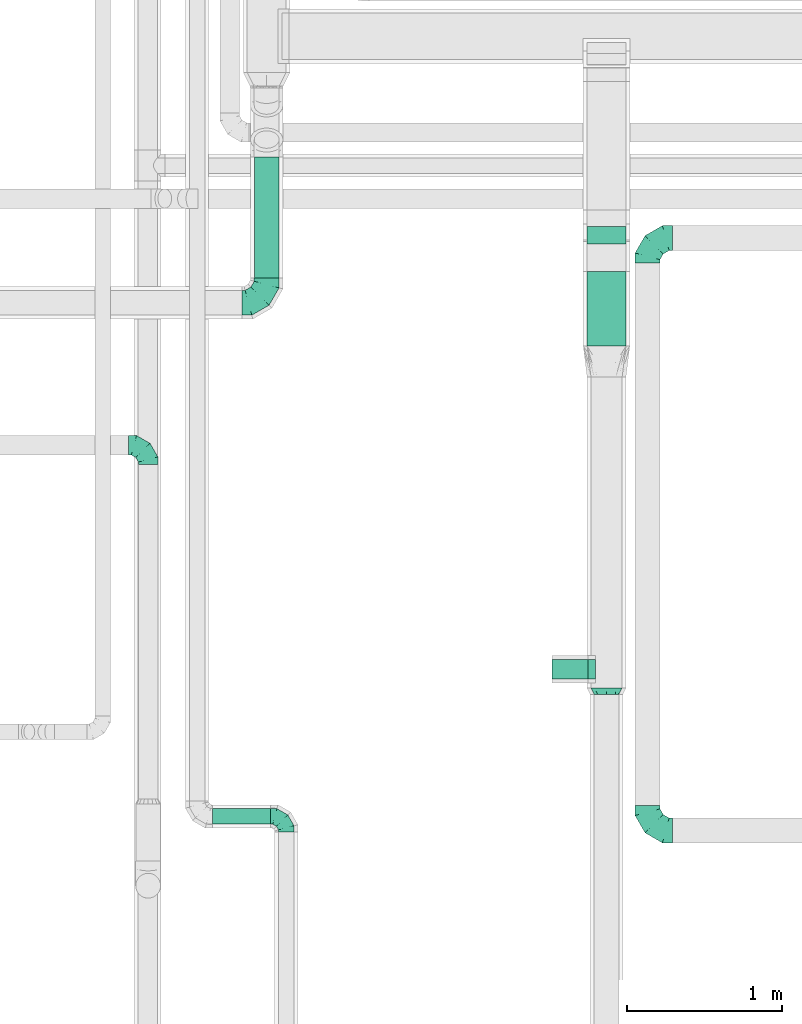
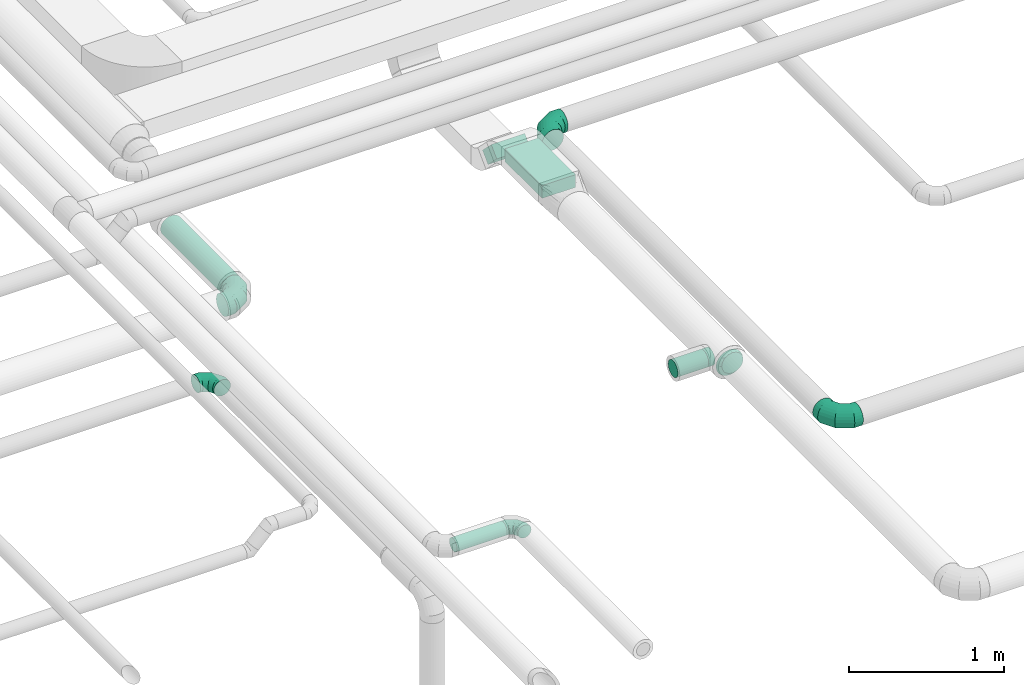
# One storey, part 61 of 92: 7 flow fittings, 5 flow segments.
"""IFC2X3 building model written with IfcOpenShell, lengths in millimetres."""

from ifc_helpers import new_model, entity, si_unit, converted_unit, derived_unit, direction, frame, origin, origin_2d_with_axis, place, context, subcontext, project, spatial, rectangle, circle, extrude, faceted_brep, source, transform, mapped, material, type_object, type_shapes, element, save


model = new_model("IFC2X3")

# Units and contexts
model_context = context("Model", 3, precision=0.01, world=origin(), true_north=direction((6.12303176911189e-17, 1.0)))
body_context = subcontext(model_context, "Body", "Model", "MODEL_VIEW")
ifc_project = project(units=[si_unit("LENGTHUNIT", "METRE", prefix="MILLI"), si_unit("AREAUNIT", "SQUARE_METRE"), si_unit("VOLUMEUNIT", "CUBIC_METRE"), converted_unit("PLANEANGLEUNIT", "DEGREE", entity("IfcRatioMeasure", 0.0174532925199433), si_unit("PLANEANGLEUNIT", "RADIAN"), dimensions=[0, 0, 0, 0, 0, 0, 0]), si_unit("MASSUNIT", "GRAM", prefix="KILO"), derived_unit("MASSDENSITYUNIT", [(si_unit("MASSUNIT", "GRAM", prefix="KILO"), 1), (si_unit("LENGTHUNIT", "METRE"), -3)]), derived_unit("MOMENTOFINERTIAUNIT", [(si_unit("LENGTHUNIT", "METRE"), 4)]), si_unit("TIMEUNIT", "SECOND"), si_unit("FREQUENCYUNIT", "HERTZ"), si_unit("THERMODYNAMICTEMPERATUREUNIT", "DEGREE_CELSIUS"), derived_unit("THERMALTRANSMITTANCEUNIT", [(si_unit("MASSUNIT", "GRAM", prefix="KILO"), 1), (si_unit("THERMODYNAMICTEMPERATUREUNIT", "KELVIN"), -1), (si_unit("TIMEUNIT", "SECOND"), -3)]), derived_unit("VOLUMETRICFLOWRATEUNIT", [(si_unit("LENGTHUNIT", "METRE"), 3), (si_unit("TIMEUNIT", "SECOND"), -1)]), derived_unit("MASSFLOWRATEUNIT", [(si_unit("MASSUNIT", "GRAM", prefix="KILO"), 1), (si_unit("TIMEUNIT", "SECOND"), -1)]), derived_unit("ROTATIONALFREQUENCYUNIT", [(si_unit("TIMEUNIT", "SECOND"), -1)]), si_unit("ELECTRICCURRENTUNIT", "AMPERE"), si_unit("ELECTRICVOLTAGEUNIT", "VOLT"), si_unit("POWERUNIT", "WATT"), si_unit("FORCEUNIT", "NEWTON", prefix="KILO"), si_unit("ILLUMINANCEUNIT", "LUX"), si_unit("LUMINOUSFLUXUNIT", "LUMEN"), si_unit("LUMINOUSINTENSITYUNIT", "CANDELA"), derived_unit("USERDEFINED", [(si_unit("MASSUNIT", "GRAM", prefix="KILO"), -1), (si_unit("LENGTHUNIT", "METRE"), -2), (si_unit("TIMEUNIT", "SECOND"), 3), (si_unit("LUMINOUSFLUXUNIT", "LUMEN"), 1)]), derived_unit("LINEARVELOCITYUNIT", [(si_unit("LENGTHUNIT", "METRE"), 1), (si_unit("TIMEUNIT", "SECOND"), -1)]), si_unit("PRESSUREUNIT", "PASCAL"), derived_unit("USERDEFINED", [(si_unit("LENGTHUNIT", "METRE"), -2), (si_unit("MASSUNIT", "GRAM", prefix="KILO"), 1), (si_unit("TIMEUNIT", "SECOND"), -2)]), derived_unit("LINEARFORCEUNIT", [(si_unit("MASSUNIT", "GRAM", prefix="KILO"), 1), (si_unit("LENGTHUNIT", "METRE"), 1), (si_unit("TIMEUNIT", "SECOND"), -2), (si_unit("LENGTHUNIT", "METRE"), -1)]), derived_unit("PLANARFORCEUNIT", [(si_unit("MASSUNIT", "GRAM", prefix="KILO"), 1), (si_unit("LENGTHUNIT", "METRE"), 1), (si_unit("TIMEUNIT", "SECOND"), -2), (si_unit("LENGTHUNIT", "METRE"), -2)])], contexts=[model_context])

# Site, building, storey
site_placement = place(None, origin())
site = spatial("IfcSite", under=ifc_project, at=site_placement, CompositionType="ELEMENT")
building_placement = place(site_placement, origin())
building = spatial("IfcBuilding", under=site, at=building_placement, CompositionType="ELEMENT")
storey_placement = place(building_placement, frame((0.0, 0.0, 4200.0)))
storey = spatial("IfcBuildingStorey", under=building, at=storey_placement, CompositionType="ELEMENT", Elevation=4200.0)

# Flow segments
duct_segment_type_1 = type_object("IfcDuctSegmentType", PredefinedType="NOTDEFINED")
flow_segment_1_placement = place(storey_placement, frame((63146.35, 7581.43, 3200.0)))
element("IfcFlowSegment", 1, at=flow_segment_1_placement, inside=storey, type_object=duct_segment_type_1, context=body_context, shape_type="SweptSolid", body=[
    extrude(rectangle(XDim=479.437287525339, YDim=250.000000000004, at=origin_2d_with_axis()), frame((125.0, 239.72, 0.0), z_axis=(0.0, 0.0, 1.0), x_axis=(0.0, 1.0, 0.0)), (0.0, 0.0, 1.0), 99.9999999999989),
])
flow_segment_2_placement = place(storey_placement, frame((63146.35, 8166.93, 3043.22)))
element("IfcFlowSegment", 2, at=flow_segment_2_placement, inside=storey, type_object=duct_segment_type_1, context=body_context, shape_type="SweptSolid", body=[
    extrude(rectangle(XDim=159.583694396644, YDim=100.000000000001, at=origin_2d_with_axis()), frame((0.0, 91.78, 91.78), z_axis=(1.0, 0.0, 0.0), x_axis=(0.0, -0.707106781186456, 0.707106781186639)), (0.0, 0.0, 1.0), 249.999999999995),
])
duct_segment_type_2 = type_object("IfcDuctSegmentType", PredefinedType="NOTDEFINED")
flow_segment_3_placement = place(storey_placement, frame((62921.35, 5437.67, 3135.9)))
element("IfcFlowSegment", 3, at=flow_segment_3_placement, inside=storey, type_object=duct_segment_type_2, context=body_context, shape_type="SweptSolid", body=[
    extrude(circle(Radius=62.5, at=origin_2d_with_axis()), frame((0.0, 64.1, 64.1), z_axis=(1.0, 0.0, 0.0), x_axis=(0.0, 1.0, 0.0)), (0.0, 0.0, 1.0), 230.000000000112),
])
flow_segment_4_placement = place(storey_placement, frame((60737.13, 4503.9, 3098.4)))
element("IfcFlowSegment", 4, at=flow_segment_4_placement, inside=storey, type_object=duct_segment_type_2, context=body_context, shape_type="SweptSolid", body=[
    extrude(circle(Radius=50.0, at=origin_2d_with_axis()), frame((0.0, 51.6, 51.6), z_axis=(1.0, 0.0, 0.0), x_axis=(0.0, -1.0, 0.0)), (0.0, 0.0, 1.0), 373.842510000017),
])
flow_segment_5_placement = place(storey_placement, frame((61003.4, 8019.85, 2888.4)))
element("IfcFlowSegment", 5, at=flow_segment_5_placement, inside=storey, type_object=duct_segment_type_2, context=body_context, shape_type="SweptSolid", body=[
    extrude(circle(Radius=80.0, at=origin_2d_with_axis()), frame((81.6, 0.0, 81.6), z_axis=(0.0, 1.0, 0.0), x_axis=(1.0, 0.0, 0.0)), (0.0, 0.0, 1.0), 776.794777815468),
])

# Flow fittings
ifc_material = material()
duct_fitting_type_1 = type_object("IfcDuctFittingType", PredefinedType="NOTDEFINED", material=ifc_material)
shared_shape_1 = source(origin(), body_context, "Body", "Brep", [
    faceted_brep([(-160.0, 0.0, -80.0), (-160.0, -20.71, -77.27), (-160.0, -40.0, -69.28), (-160.0, -56.57, -56.57), (-160.0, -69.28, -40.0), (-160.0, -77.27, -20.71), (-160.0, -80.0, 0.0), (-160.0, -77.27, 20.71), (-160.0, -69.28, 40.0), (-160.0, -56.57, 56.57), (-160.0, -40.0, 69.28), (-160.0, -20.71, 77.27), (-160.0, 0.0, 80.0), (-160.0, 20.71, 77.27), (-160.0, 40.0, 69.28), (-160.0, 56.57, 56.57), (-160.0, 69.28, 40.0), (-160.0, 77.27, 20.71), (-160.0, 80.0, 0.0), (-160.0, 77.27, -20.71), (-160.0, 69.28, -40.0), (-160.0, 56.57, -56.57), (-160.0, 40.0, -69.28), (-160.0, 20.71, -77.27), (-122.68, 20.71, 77.27), (-127.85, 40.0, 69.28), (-117.13, 0.0, 80.0), (-132.29, 56.57, 56.57), (-137.83, 77.27, 20.71), (-138.56, 80.0, 0.0), (-135.69, 69.28, 40.0), (-135.69, 69.28, -40.0), (-132.29, 56.57, -56.57), (-137.83, 77.27, -20.71), (-122.68, 20.71, -77.27), (-117.13, 0.0, -80.0), (-127.85, 40.0, -69.28), (-111.58, -20.71, -77.27), (-106.41, -40.0, -69.28), (-101.97, -56.57, -56.57), (-98.56, -69.28, -40.0), (-96.42, -77.27, -20.71), (-95.69, -80.0, 0.0), (-96.42, -77.27, 20.71), (-98.56, -69.28, 40.0), (-101.97, -56.57, 56.57), (-106.41, -40.0, 69.28), (-111.58, -20.71, 77.27), (-58.03, 58.03, 77.27), (-72.15, 72.15, 69.28), (-42.87, 42.87, 80.0), (-84.28, 84.28, 56.57), (-93.59, 93.59, 40.0), (-99.44, 99.44, 20.71), (-101.44, 101.44, 0.0), (-99.44, 99.44, -20.71), (-93.59, 93.59, -40.0), (-84.28, 84.28, -56.57), (-58.03, 58.03, -77.27), (-42.87, 42.87, -80.0), (-72.15, 72.15, -69.28), (-27.71, 27.71, -77.27), (-13.59, 13.59, -69.28), (-1.46, 1.46, -56.57), (7.85, -7.85, -40.0), (13.7, -13.7, -20.71), (15.69, -15.69, 0.0), (13.7, -13.7, 20.71), (7.85, -7.85, 40.0), (-1.46, 1.46, 56.57), (-13.59, 13.59, 69.28), (-27.71, 27.71, 77.27), (-20.71, 122.68, 77.27), (-40.0, 127.85, 69.28), (0.0, 117.13, 80.0), (-56.57, 132.29, 56.57), (-69.28, 135.69, 40.0), (-77.27, 137.83, 20.71), (-80.0, 138.56, 0.0), (-77.27, 137.83, -20.71), (-69.28, 135.69, -40.0), (-56.57, 132.29, -56.57), (-20.71, 122.68, -77.27), (0.0, 117.13, -80.0), (-40.0, 127.85, -69.28), (20.71, 111.58, -77.27), (40.0, 106.41, -69.28), (56.57, 101.97, -56.57), (69.28, 98.56, -40.0), (77.27, 96.42, -20.71), (80.0, 95.69, 0.0), (77.27, 96.42, 20.71), (69.28, 98.56, 40.0), (56.57, 101.97, 56.57), (40.0, 106.41, 69.28), (20.71, 111.58, 77.27), (-20.71, 160.0, -77.27), (-40.0, 160.0, -69.28), (-56.57, 160.0, -56.57), (-69.28, 160.0, -40.0), (-77.27, 160.0, -20.71), (-80.0, 160.0, 0.0), (-77.27, 160.0, 20.71), (-69.28, 160.0, 40.0), (-56.57, 160.0, 56.57), (-40.0, 160.0, 69.28), (-20.71, 160.0, 77.27), (0.0, 160.0, 80.0), (20.71, 160.0, 77.27), (40.0, 160.0, 69.28), (56.57, 160.0, 56.57), (69.28, 160.0, 40.0), (77.27, 160.0, 20.71), (80.0, 160.0, 0.0), (77.27, 160.0, -20.71), (69.28, 160.0, -40.0), (56.57, 160.0, -56.57), (40.0, 160.0, -69.28), (20.71, 160.0, -77.27), (0.0, 160.0, -80.0)], [[[0, 1, 2, 3, 4, 5, 6, 7, 8, 9, 10, 11, 12, 13, 14, 15, 16, 17, 18, 19, 20, 21, 22, 23]], [[24, 25, 14, 13]], [[26, 24, 13, 12]], [[14, 25, 27, 15]], [[28, 29, 18, 17]], [[30, 28, 17, 16]], [[15, 27, 30, 16]], [[20, 31, 32, 21]], [[33, 31, 20, 19]], [[18, 29, 33, 19]], [[34, 35, 0, 23]], [[36, 34, 23, 22]], [[32, 36, 22, 21]], [[1, 0, 35, 37]], [[2, 1, 37, 38]], [[3, 2, 38, 39]], [[5, 4, 40, 41]], [[6, 5, 41, 42]], [[39, 40, 4, 3]], [[6, 42, 43, 7]], [[7, 43, 44, 8]], [[8, 44, 45, 9]], [[9, 45, 46, 10]], [[10, 46, 47, 11]], [[26, 12, 11, 47]], [[48, 49, 25, 24]], [[50, 48, 24, 26]], [[27, 25, 49, 51]], [[52, 53, 28, 30]], [[51, 52, 30, 27]], [[29, 28, 53, 54]], [[55, 56, 31, 33]], [[54, 55, 33, 29]], [[32, 31, 56, 57]], [[58, 59, 35, 34]], [[60, 58, 34, 36]], [[57, 60, 36, 32]], [[37, 35, 59, 61]], [[38, 37, 61, 62]], [[39, 38, 62, 63]], [[41, 40, 64, 65]], [[42, 41, 65, 66]], [[63, 64, 40, 39]], [[43, 42, 66, 67]], [[44, 43, 67, 68]], [[68, 69, 45, 44]], [[46, 45, 69, 70]], [[47, 46, 70, 71]], [[26, 47, 71, 50]], [[72, 73, 49, 48]], [[74, 72, 48, 50]], [[51, 49, 73, 75]], [[76, 77, 53, 52]], [[75, 76, 52, 51]], [[54, 53, 77, 78]], [[79, 80, 56, 55]], [[78, 79, 55, 54]], [[57, 56, 80, 81]], [[82, 83, 59, 58]], [[84, 82, 58, 60]], [[81, 84, 60, 57]], [[61, 59, 83, 85]], [[62, 61, 85, 86]], [[63, 62, 86, 87]], [[65, 64, 88, 89]], [[66, 65, 89, 90]], [[87, 88, 64, 63]], [[67, 66, 90, 91]], [[68, 67, 91, 92]], [[92, 93, 69, 68]], [[70, 69, 93, 94]], [[71, 70, 94, 95]], [[50, 71, 95, 74]], [[96, 97, 98, 99, 100, 101, 102, 103, 104, 105, 106, 107, 108, 109, 110, 111, 112, 113, 114, 115, 116, 117, 118, 119]], [[72, 74, 107, 106]], [[73, 72, 106, 105]], [[75, 73, 105, 104]], [[77, 76, 103, 102]], [[78, 77, 102, 101]], [[75, 104, 103, 76]], [[78, 101, 100, 79]], [[79, 100, 99, 80]], [[80, 99, 98, 81]], [[84, 97, 96, 82]], [[82, 96, 119, 83]], [[84, 81, 98, 97]], [[118, 117, 86, 85]], [[119, 118, 85, 83]], [[116, 87, 86, 117]], [[88, 115, 114, 89]], [[89, 114, 113, 90]], [[115, 88, 87, 116]], [[112, 111, 92, 91]], [[113, 112, 91, 90]], [[111, 110, 93, 92]], [[95, 94, 109, 108]], [[74, 95, 108, 107]], [[110, 109, 94, 93]]]),
])
type_shapes(duct_fitting_type_1, [shared_shape_1])
for number, where, z_axis, x_axis in (
    (6, (63535.27, 4465.46, 3200.0), (0.0, 0.0, 1.0), (0.0, -1.0, 0.0)),
    (7, (63535.27, 8275.8, 3200.0), (0.0, 0.0, 1.0), (-1.0, 0.0, 0.0)),
):
    element("IfcFlowFitting", number, at=place(storey_placement, frame(where, z_axis=z_axis, x_axis=x_axis)), inside=storey, type_object=duct_fitting_type_1, material=ifc_material, context=body_context, shape_type="MappedRepresentation", body=[
        mapped(shared_shape_1, transform((0.0, 0.0, 0.0), scale=1.0)),
    ])
flow_fitting_1_placement = place(storey_placement, frame((61085.0, 7859.85, 2970.0)))
element("IfcFlowFitting", 8, at=flow_fitting_1_placement, inside=storey, type_object=duct_fitting_type_1, material=ifc_material, context=body_context, shape_type="MappedRepresentation", body=[
    mapped(shared_shape_1, transform((0.0, 0.0, 0.0), scale=1.0)),
])
duct_fitting_type_2 = type_object("IfcDuctFittingType", PredefinedType="NOTDEFINED", material=ifc_material)
shared_shape_2 = source(origin(), body_context, "Body", "Brep", [
    faceted_brep([(-100.0, 0.0, -50.0), (-100.0, -12.94, -48.3), (-100.0, -25.0, -43.3), (-100.0, -35.36, -35.36), (-100.0, -43.3, -25.0), (-100.0, -48.3, -12.94), (-100.0, -50.0, 0.0), (-100.0, -48.3, 12.94), (-100.0, -43.3, 25.0), (-100.0, -35.36, 35.36), (-100.0, -25.0, 43.3), (-100.0, -12.94, 48.3), (-100.0, 0.0, 50.0), (-100.0, 12.94, 48.3), (-100.0, 25.0, 43.3), (-100.0, 35.36, 35.36), (-100.0, 43.3, 25.0), (-100.0, 48.3, 12.94), (-100.0, 50.0, 0.0), (-100.0, 48.3, -12.94), (-100.0, 43.3, -25.0), (-100.0, 35.36, -35.36), (-100.0, 25.0, -43.3), (-100.0, 12.94, -48.3), (-76.67, 12.94, 48.3), (-79.9, 25.0, 43.3), (-73.21, 0.0, 50.0), (-82.68, 35.36, 35.36), (-86.15, 48.3, 12.94), (-86.6, 50.0, 0.0), (-84.81, 43.3, 25.0), (-84.81, 43.3, -25.0), (-82.68, 35.36, -35.36), (-86.15, 48.3, -12.94), (-76.67, 12.94, -48.3), (-73.21, 0.0, -50.0), (-79.9, 25.0, -43.3), (-69.74, -12.94, -48.3), (-66.51, -25.0, -43.3), (-63.73, -35.36, -35.36), (-61.6, -43.3, -25.0), (-60.26, -48.3, -12.94), (-59.81, -50.0, 0.0), (-60.26, -48.3, 12.94), (-61.6, -43.3, 25.0), (-63.73, -35.36, 35.36), (-66.51, -25.0, 43.3), (-69.74, -12.94, 48.3), (-36.27, 36.27, 48.3), (-45.1, 45.1, 43.3), (-26.79, 26.79, 50.0), (-52.68, 52.68, 35.36), (-58.49, 58.49, 25.0), (-62.15, 62.15, 12.94), (-63.4, 63.4, 0.0), (-62.15, 62.15, -12.94), (-58.49, 58.49, -25.0), (-52.68, 52.68, -35.36), (-36.27, 36.27, -48.3), (-26.79, 26.79, -50.0), (-45.1, 45.1, -43.3), (-17.32, 17.32, -48.3), (-8.49, 8.49, -43.3), (-0.91, 0.91, -35.36), (4.9, -4.9, -25.0), (8.56, -8.56, -12.94), (9.81, -9.81, 0.0), (8.56, -8.56, 12.94), (4.9, -4.9, 25.0), (-0.91, 0.91, 35.36), (-8.49, 8.49, 43.3), (-17.32, 17.32, 48.3), (-12.94, 76.67, 48.3), (-25.0, 79.9, 43.3), (0.0, 73.21, 50.0), (-35.36, 82.68, 35.36), (-43.3, 84.81, 25.0), (-48.3, 86.15, 12.94), (-50.0, 86.6, 0.0), (-48.3, 86.15, -12.94), (-43.3, 84.81, -25.0), (-35.36, 82.68, -35.36), (-12.94, 76.67, -48.3), (0.0, 73.21, -50.0), (-25.0, 79.9, -43.3), (12.94, 69.74, -48.3), (25.0, 66.51, -43.3), (35.36, 63.73, -35.36), (43.3, 61.6, -25.0), (48.3, 60.26, -12.94), (50.0, 59.81, 0.0), (48.3, 60.26, 12.94), (43.3, 61.6, 25.0), (35.36, 63.73, 35.36), (25.0, 66.51, 43.3), (12.94, 69.74, 48.3), (-12.94, 100.0, -48.3), (-25.0, 100.0, -43.3), (-35.36, 100.0, -35.36), (-43.3, 100.0, -25.0), (-48.3, 100.0, -12.94), (-50.0, 100.0, 0.0), (-48.3, 100.0, 12.94), (-43.3, 100.0, 25.0), (-35.36, 100.0, 35.36), (-25.0, 100.0, 43.3), (-12.94, 100.0, 48.3), (0.0, 100.0, 50.0), (12.94, 100.0, 48.3), (25.0, 100.0, 43.3), (35.36, 100.0, 35.36), (43.3, 100.0, 25.0), (48.3, 100.0, 12.94), (50.0, 100.0, 0.0), (48.3, 100.0, -12.94), (43.3, 100.0, -25.0), (35.36, 100.0, -35.36), (25.0, 100.0, -43.3), (12.94, 100.0, -48.3), (0.0, 100.0, -50.0)], [[[0, 1, 2, 3, 4, 5, 6, 7, 8, 9, 10, 11, 12, 13, 14, 15, 16, 17, 18, 19, 20, 21, 22, 23]], [[24, 25, 14, 13]], [[26, 24, 13, 12]], [[14, 25, 27, 15]], [[28, 29, 18, 17]], [[30, 28, 17, 16]], [[15, 27, 30, 16]], [[20, 31, 32, 21]], [[33, 31, 20, 19]], [[18, 29, 33, 19]], [[34, 35, 0, 23]], [[36, 34, 23, 22]], [[32, 36, 22, 21]], [[2, 1, 37, 38]], [[3, 2, 38, 39]], [[0, 35, 37, 1]], [[5, 4, 40, 41]], [[6, 5, 41, 42]], [[3, 39, 40, 4]], [[6, 42, 43, 7]], [[7, 43, 44, 8]], [[8, 44, 45, 9]], [[10, 46, 47, 11]], [[11, 47, 26, 12]], [[10, 9, 45, 46]], [[48, 49, 25, 24]], [[50, 48, 24, 26]], [[27, 25, 49, 51]], [[52, 53, 28, 30]], [[51, 52, 30, 27]], [[29, 28, 53, 54]], [[55, 56, 31, 33]], [[54, 55, 33, 29]], [[57, 32, 31, 56]], [[58, 59, 35, 34]], [[60, 58, 34, 36]], [[57, 60, 36, 32]], [[37, 35, 59, 61]], [[38, 37, 61, 62]], [[39, 38, 62, 63]], [[41, 40, 64, 65]], [[42, 41, 65, 66]], [[63, 64, 40, 39]], [[43, 42, 66, 67]], [[44, 43, 67, 68]], [[68, 69, 45, 44]], [[46, 45, 69, 70]], [[47, 46, 70, 71]], [[26, 47, 71, 50]], [[72, 73, 49, 48]], [[74, 72, 48, 50]], [[51, 49, 73, 75]], [[76, 77, 53, 52]], [[75, 76, 52, 51]], [[54, 53, 77, 78]], [[79, 80, 56, 55]], [[78, 79, 55, 54]], [[81, 57, 56, 80]], [[82, 83, 59, 58]], [[84, 82, 58, 60]], [[81, 84, 60, 57]], [[61, 59, 83, 85]], [[62, 61, 85, 86]], [[63, 62, 86, 87]], [[65, 64, 88, 89]], [[66, 65, 89, 90]], [[87, 88, 64, 63]], [[67, 66, 90, 91]], [[68, 67, 91, 92]], [[92, 93, 69, 68]], [[70, 69, 93, 94]], [[71, 70, 94, 95]], [[50, 71, 95, 74]], [[96, 97, 98, 99, 100, 101, 102, 103, 104, 105, 106, 107, 108, 109, 110, 111, 112, 113, 114, 115, 116, 117, 118, 119]], [[72, 74, 107, 106]], [[73, 72, 106, 105]], [[75, 73, 105, 104]], [[77, 76, 103, 102]], [[78, 77, 102, 101]], [[75, 104, 103, 76]], [[78, 101, 100, 79]], [[79, 100, 99, 80]], [[80, 99, 98, 81]], [[96, 119, 83, 82]], [[97, 96, 82, 84]], [[84, 81, 98, 97]], [[83, 119, 118, 85]], [[85, 118, 117, 86]], [[86, 117, 116, 87]], [[88, 115, 114, 89]], [[89, 114, 113, 90]], [[87, 116, 115, 88]], [[91, 90, 113, 112]], [[92, 91, 112, 111]], [[93, 92, 111, 110]], [[95, 94, 109, 108]], [[74, 95, 108, 107]], [[110, 109, 94, 93]]]),
])
type_shapes(duct_fitting_type_2, [shared_shape_2])
flow_fitting_2_placement = place(storey_placement, frame((61210.97, 4555.49, 3150.0), z_axis=(0.0, 0.0, 1.0), x_axis=(0.0, 1.0, 0.0)))
element("IfcFlowFitting", 9, at=flow_fitting_2_placement, inside=storey, type_object=duct_fitting_type_2, material=ifc_material, context=body_context, shape_type="MappedRepresentation", body=[
    mapped(shared_shape_2, transform((0.0, 0.0, 0.0), scale=1.0)),
])
duct_fitting_type_3 = type_object("IfcDuctFittingType", PredefinedType="NOTDEFINED", material=ifc_material)
shared_shape_3 = source(origin(), body_context, "Body", "Brep", [
    faceted_brep([(-125.0, 0.0, -62.5), (-125.0, -16.18, -60.37), (-125.0, -31.25, -54.13), (-125.0, -44.19, -44.19), (-125.0, -54.13, -31.25), (-125.0, -60.37, -16.18), (-125.0, -62.5, 0.0), (-125.0, -60.37, 16.18), (-125.0, -54.13, 31.25), (-125.0, -44.19, 44.19), (-125.0, -31.25, 54.13), (-125.0, -16.18, 60.37), (-125.0, 0.0, 62.5), (-125.0, 16.18, 60.37), (-125.0, 31.25, 54.13), (-125.0, 44.19, 44.19), (-125.0, 54.13, 31.25), (-125.0, 60.37, 16.18), (-125.0, 62.5, 0.0), (-125.0, 60.37, -16.18), (-125.0, 54.13, -31.25), (-125.0, 44.19, -44.19), (-125.0, 31.25, -54.13), (-125.0, 16.18, -60.37), (-95.84, 16.18, 60.37), (-99.88, 31.25, 54.13), (-91.51, 0.0, 62.5), (-103.35, 44.19, 44.19), (-107.68, 60.37, 16.18), (-108.25, 62.5, 0.0), (-106.01, 54.13, 31.25), (-106.01, 54.13, -31.25), (-103.35, 44.19, -44.19), (-107.68, 60.37, -16.18), (-95.84, 16.18, -60.37), (-91.51, 0.0, -62.5), (-99.88, 31.25, -54.13), (-87.17, -16.18, -60.37), (-83.13, -31.25, -54.13), (-79.66, -44.19, -44.19), (-77.0, -54.13, -31.25), (-75.33, -60.37, -16.18), (-74.76, -62.5, 0.0), (-75.33, -60.37, 16.18), (-77.0, -54.13, 31.25), (-79.66, -44.19, 44.19), (-83.13, -31.25, 54.13), (-87.17, -16.18, 60.37), (-45.34, 45.34, 60.37), (-56.37, 56.37, 54.13), (-33.49, 33.49, 62.5), (-65.85, 65.85, 44.19), (-73.12, 73.12, 31.25), (-77.69, 77.69, 16.18), (-79.25, 79.25, 0.0), (-77.69, 77.69, -16.18), (-73.12, 73.12, -31.25), (-65.85, 65.85, -44.19), (-45.34, 45.34, -60.37), (-33.49, 33.49, -62.5), (-56.37, 56.37, -54.13), (-21.65, 21.65, -60.37), (-10.62, 10.62, -54.13), (-1.14, 1.14, -44.19), (6.13, -6.13, -31.25), (10.7, -10.7, -16.18), (12.26, -12.26, 0.0), (10.7, -10.7, 16.18), (6.13, -6.13, 31.25), (-1.14, 1.14, 44.19), (-10.62, 10.62, 54.13), (-21.65, 21.65, 60.37), (-16.18, 95.84, 60.37), (-31.25, 99.88, 54.13), (0.0, 91.51, 62.5), (-44.19, 103.35, 44.19), (-54.13, 106.01, 31.25), (-60.37, 107.68, 16.18), (-62.5, 108.25, 0.0), (-60.37, 107.68, -16.18), (-54.13, 106.01, -31.25), (-44.19, 103.35, -44.19), (-16.18, 95.84, -60.37), (0.0, 91.51, -62.5), (-31.25, 99.88, -54.13), (16.18, 87.17, -60.37), (31.25, 83.13, -54.13), (44.19, 79.66, -44.19), (54.13, 77.0, -31.25), (60.37, 75.33, -16.18), (62.5, 74.76, 0.0), (60.37, 75.33, 16.18), (54.13, 77.0, 31.25), (44.19, 79.66, 44.19), (31.25, 83.13, 54.13), (16.18, 87.17, 60.37), (-16.18, 125.0, -60.37), (-31.25, 125.0, -54.13), (-44.19, 125.0, -44.19), (-54.13, 125.0, -31.25), (-60.37, 125.0, -16.18), (-62.5, 125.0, 0.0), (-60.37, 125.0, 16.18), (-54.13, 125.0, 31.25), (-44.19, 125.0, 44.19), (-31.25, 125.0, 54.13), (-16.18, 125.0, 60.37), (0.0, 125.0, 62.5), (16.18, 125.0, 60.37), (31.25, 125.0, 54.13), (44.19, 125.0, 44.19), (54.13, 125.0, 31.25), (60.37, 125.0, 16.18), (62.5, 125.0, 0.0), (60.37, 125.0, -16.18), (54.13, 125.0, -31.25), (44.19, 125.0, -44.19), (31.25, 125.0, -54.13), (16.18, 125.0, -60.37), (0.0, 125.0, -62.5)], [[[0, 1, 2, 3, 4, 5, 6, 7, 8, 9, 10, 11, 12, 13, 14, 15, 16, 17, 18, 19, 20, 21, 22, 23]], [[24, 25, 14, 13]], [[26, 24, 13, 12]], [[14, 25, 27, 15]], [[28, 29, 18, 17]], [[30, 28, 17, 16]], [[15, 27, 30, 16]], [[20, 31, 32, 21]], [[33, 31, 20, 19]], [[18, 29, 33, 19]], [[34, 35, 0, 23]], [[36, 34, 23, 22]], [[21, 32, 36, 22]], [[1, 0, 35, 37]], [[2, 1, 37, 38]], [[38, 39, 3, 2]], [[5, 4, 40, 41]], [[6, 5, 41, 42]], [[39, 40, 4, 3]], [[6, 42, 43, 7]], [[7, 43, 44, 8]], [[45, 9, 8, 44]], [[9, 45, 46, 10]], [[10, 46, 47, 11]], [[26, 12, 11, 47]], [[48, 49, 25, 24]], [[50, 48, 24, 26]], [[27, 25, 49, 51]], [[52, 53, 28, 30]], [[51, 52, 30, 27]], [[29, 28, 53, 54]], [[55, 56, 31, 33]], [[54, 55, 33, 29]], [[57, 32, 31, 56]], [[58, 59, 35, 34]], [[60, 58, 34, 36]], [[57, 60, 36, 32]], [[37, 35, 59, 61]], [[38, 37, 61, 62]], [[39, 38, 62, 63]], [[41, 40, 64, 65]], [[42, 41, 65, 66]], [[63, 64, 40, 39]], [[43, 42, 66, 67]], [[44, 43, 67, 68]], [[68, 69, 45, 44]], [[46, 45, 69, 70]], [[47, 46, 70, 71]], [[26, 47, 71, 50]], [[72, 73, 49, 48]], [[74, 72, 48, 50]], [[51, 49, 73, 75]], [[76, 77, 53, 52]], [[75, 76, 52, 51]], [[54, 53, 77, 78]], [[79, 80, 56, 55]], [[78, 79, 55, 54]], [[81, 57, 56, 80]], [[82, 83, 59, 58]], [[84, 82, 58, 60]], [[81, 84, 60, 57]], [[61, 59, 83, 85]], [[62, 61, 85, 86]], [[63, 62, 86, 87]], [[65, 64, 88, 89]], [[66, 65, 89, 90]], [[87, 88, 64, 63]], [[67, 66, 90, 91]], [[68, 67, 91, 92]], [[92, 93, 69, 68]], [[70, 69, 93, 94]], [[71, 70, 94, 95]], [[50, 71, 95, 74]], [[96, 97, 98, 99, 100, 101, 102, 103, 104, 105, 106, 107, 108, 109, 110, 111, 112, 113, 114, 115, 116, 117, 118, 119]], [[72, 74, 107, 106]], [[73, 72, 106, 105]], [[75, 73, 105, 104]], [[77, 76, 103, 102]], [[78, 77, 102, 101]], [[75, 104, 103, 76]], [[78, 101, 100, 79]], [[79, 100, 99, 80]], [[80, 99, 98, 81]], [[96, 119, 83, 82]], [[97, 96, 82, 84]], [[84, 81, 98, 97]], [[83, 119, 118, 85]], [[85, 118, 117, 86]], [[116, 87, 86, 117]], [[88, 115, 114, 89]], [[89, 114, 113, 90]], [[115, 88, 87, 116]], [[91, 90, 113, 112]], [[92, 91, 112, 111]], [[111, 110, 93, 92]], [[95, 94, 109, 108]], [[74, 95, 108, 107]], [[110, 109, 94, 93]]]),
])
type_shapes(duct_fitting_type_3, [shared_shape_3])
flow_fitting_3_placement = place(storey_placement, frame((60322.71, 6943.28, 3160.0), z_axis=(0.0, 0.0, 1.0), x_axis=(0.0, 1.0, 0.0)))
element("IfcFlowFitting", 10, at=flow_fitting_3_placement, inside=storey, type_object=duct_fitting_type_3, material=ifc_material, context=body_context, shape_type="MappedRepresentation", body=[
    mapped(shared_shape_3, transform((0.0, 0.0, 0.0), scale=1.0)),
])
duct_fitting_type_4 = type_object("IfcDuctFittingType", PredefinedType="NOTDEFINED", material=ifc_material)
shared_shape_4 = source(origin(), body_context, "Body", "Brep", [
    faceted_brep([(20.0, 16.18, -60.37), (20.0, 31.25, -54.13), (20.0, 44.19, -44.19), (20.0, 54.13, -31.25), (20.0, 60.37, -16.18), (20.0, 62.5, 0.0), (20.0, 60.37, 16.18), (20.0, 54.13, 31.25), (20.0, 44.19, 44.19), (20.0, 31.25, 54.13), (20.0, 16.18, 60.37), (20.0, 0.0, 62.5), (20.0, -16.18, 60.37), (20.0, -31.25, 54.13), (20.0, -44.19, 44.19), (20.0, -54.13, 31.25), (20.0, -60.37, 16.18), (20.0, -62.5, 0.0), (20.0, -60.37, -16.18), (20.0, -54.13, -31.25), (20.0, -44.19, -44.19), (20.0, -31.25, -54.13), (20.0, -16.18, -60.37), (20.0, 0.0, -62.5), (0.0, 0.0, 62.5), (0.0, 16.18, 60.37), (-28.03, 16.18, 60.37), (-28.03, 0.0, 62.5), (0.0, 31.25, 54.13), (-28.03, 31.25, 54.13), (0.0, 44.19, 44.19), (-28.03, 44.19, 44.19), (0.0, 54.13, 31.25), (0.0, 60.37, 16.18), (-28.03, 60.37, 16.18), (-28.03, 54.13, 31.25), (0.0, 62.5, 0.0), (-28.03, 62.5, 0.0), (0.0, 60.37, -16.18), (-28.03, 60.37, -16.18), (0.0, 54.13, -31.25), (-28.03, 54.13, -31.25), (0.0, 44.19, -44.19), (-28.03, 44.19, -44.19), (0.0, 31.25, -54.13), (0.0, 16.18, -60.37), (-28.03, 16.18, -60.37), (-28.03, 31.25, -54.13), (0.0, 0.0, -62.5), (-28.03, 0.0, -62.5), (0.0, -16.18, -60.37), (-28.03, -16.18, -60.37), (0.0, -31.25, -54.13), (-28.03, -31.25, -54.13), (0.0, -44.19, -44.19), (-28.03, -44.19, -44.19), (0.0, -54.13, -31.25), (0.0, -60.37, -16.18), (-28.03, -60.37, -16.18), (-28.03, -54.13, -31.25), (0.0, -62.5, 0.0), (-28.03, -62.5, 0.0), (0.0, -60.37, 16.18), (-28.03, -60.37, 16.18), (0.0, -54.13, 31.25), (-28.03, -54.13, 31.25), (0.0, -44.19, 44.19), (-28.03, -44.19, 44.19), (0.0, -31.25, 54.13), (0.0, -16.18, 60.37), (-28.03, -16.18, 60.37), (-28.03, -31.25, 54.13)], [[[0, 1, 2, 3, 4, 5, 6, 7, 8, 9, 10, 11, 12, 13, 14, 15, 16, 17, 18, 19, 20, 21, 22, 23]], [[24, 11, 10, 25, 26, 27]], [[25, 10, 9, 28, 29, 26]], [[28, 9, 8, 30, 31, 29]], [[32, 7, 6, 33, 34, 35]], [[33, 6, 5, 36, 37, 34]], [[30, 8, 7, 32, 35, 31]], [[36, 5, 4, 38, 39, 37]], [[38, 4, 3, 40, 41, 39]], [[40, 3, 2, 42, 43, 41]], [[44, 1, 0, 45, 46, 47]], [[45, 0, 23, 48, 49, 46]], [[42, 2, 1, 44, 47, 43]], [[48, 23, 22, 50, 51, 49]], [[50, 22, 21, 52, 53, 51]], [[52, 21, 20, 54, 55, 53]], [[56, 19, 18, 57, 58, 59]], [[57, 18, 17, 60, 61, 58]], [[54, 20, 19, 56, 59, 55]], [[60, 17, 16, 62, 63, 61]], [[62, 16, 15, 64, 65, 63]], [[64, 15, 14, 66, 67, 65]], [[68, 13, 12, 69, 70, 71]], [[69, 12, 11, 24, 27, 70]], [[66, 14, 13, 68, 71, 67]], [[49, 51, 53, 55, 59, 58, 61, 63, 65, 67, 71, 70, 27, 26, 29, 31, 35, 34, 37, 39, 41, 43, 47, 46]]]),
])
type_shapes(duct_fitting_type_4, [shared_shape_4])
flow_fitting_4_placement = place(storey_placement, frame((63171.35, 5501.76, 3200.0), z_axis=(0.0, 0.0, -1.0), x_axis=(-1.0, 0.0, 0.0)))
element("IfcFlowFitting", 11, at=flow_fitting_4_placement, inside=storey, type_object=duct_fitting_type_4, material=ifc_material, context=body_context, shape_type="MappedRepresentation", body=[
    mapped(shared_shape_4, transform((0.0, 0.0, 0.0), scale=1.0)),
])
duct_fitting_type_5 = type_object("IfcDuctFittingType", PredefinedType="NOTDEFINED", material=ifc_material)
shared_shape_5 = source(origin(), body_context, "Body", "Brep", [
    faceted_brep([(40.0, -58.78, -100.9), (40.0, -30.9, -115.11), (40.0, 0.0, -120.0), (40.0, 30.9, -115.11), (40.0, 58.78, -100.9), (40.0, 80.9, -78.78), (40.0, 95.11, -50.9), (40.0, 100.0, -20.0), (40.0, 95.11, 10.9), (40.0, 80.9, 38.78), (40.0, 58.78, 60.9), (40.0, 30.9, 75.11), (40.0, 0.0, 80.0), (40.0, -30.9, 75.11), (40.0, -58.78, 60.9), (40.0, -80.9, 38.78), (40.0, -95.11, 10.9), (40.0, -100.0, -20.0), (40.0, -95.11, -50.9), (40.0, -80.9, -78.78), (0.0, -56.57, -56.57), (0.0, -65.24, -43.59), (0.0, -73.91, -30.61), (0.0, -76.96, -15.31), (0.0, -80.0, 0.0), (0.0, -76.96, 15.31), (0.0, -73.91, 30.61), (0.0, -65.24, 43.59), (0.0, -56.57, 56.57), (0.0, -43.59, 65.24), (0.0, -30.61, 73.91), (0.0, -15.31, 76.96), (0.0, 0.0, 80.0), (0.0, 15.31, 76.96), (0.0, 30.61, 73.91), (0.0, 43.59, 65.24), (0.0, 56.57, 56.57), (0.0, 65.24, 43.59), (0.0, 73.91, 30.61), (0.0, 76.96, 15.31), (0.0, 80.0, 0.0), (0.0, 76.96, -15.31), (0.0, 73.91, -30.61), (0.0, 65.24, -43.59), (0.0, 56.57, -56.57), (0.0, 43.59, -65.24), (0.0, 30.61, -73.91), (0.0, 15.31, -76.96), (0.0, 0.0, -80.0), (0.0, -15.31, -76.96), (0.0, -30.61, -73.91), (0.0, -43.59, -65.24), (18.77, 85.54, 16.56), (20.0, 90.0, -10.0), (18.17, 89.08, -9.08), (19.3, 77.72, 35.03), (21.23, 42.72, 69.3), (21.05, 67.33, 49.98), (18.5, 24.79, 76.49), (18.17, 0.0, 80.0), (20.0, 0.0, 80.0), (18.77, -25.95, 76.15), (19.3, -44.68, 68.07), (21.23, -79.92, 32.1), (21.05, -60.51, 56.81), (18.5, -85.74, 15.55), (16.11, -88.06, -8.06), (20.0, -90.0, -10.0), (18.77, -85.54, -35.33), (19.3, -77.72, -54.33), (21.05, -67.33, -71.03), (18.5, -24.79, -94.98), (21.23, -42.72, -90.53), (16.11, 0.0, -96.11), (20.0, 0.0, -100.0), (18.77, 25.95, -94.92), (19.3, 44.68, -87.37), (21.05, 60.51, -77.86), (18.5, 85.74, -34.04), (21.23, 79.92, -53.33)], [[[0, 1, 2, 3, 4, 5, 6, 7, 8, 9, 10, 11, 12, 13, 14, 15, 16, 17, 18, 19]], [[20, 21, 22, 23, 24, 25, 26, 27, 28, 29, 30, 31, 32, 33, 34, 35, 36, 37, 38, 39, 40, 41, 42, 43, 44, 45, 46, 47, 48, 49, 50, 51]], [[52, 7, 53, 54]], [[39, 38, 52]], [[52, 38, 55]], [[54, 39, 52]], [[52, 55, 8]], [[54, 40, 39]], [[9, 8, 55]], [[34, 56, 35]], [[35, 57, 36]], [[52, 8, 7]], [[37, 57, 55]], [[56, 58, 11]], [[57, 56, 10]], [[12, 11, 58]], [[35, 56, 57]], [[57, 37, 36]], [[58, 56, 34]], [[57, 9, 55]], [[11, 10, 56]], [[10, 9, 57]], [[58, 34, 33]], [[33, 32, 59, 60]], [[55, 38, 37]], [[60, 12, 58]], [[33, 60, 58]], [[61, 12, 60, 59]], [[31, 30, 61]], [[61, 30, 62]], [[59, 31, 61]], [[61, 62, 13]], [[59, 32, 31]], [[14, 13, 62]], [[26, 63, 27]], [[27, 64, 28]], [[61, 13, 12]], [[29, 64, 62]], [[63, 65, 16]], [[64, 63, 15]], [[17, 16, 65]], [[27, 63, 64]], [[64, 29, 28]], [[65, 63, 26]], [[64, 14, 62]], [[16, 15, 63]], [[15, 14, 64]], [[65, 26, 25]], [[25, 24, 66, 67]], [[62, 30, 29]], [[67, 17, 65]], [[25, 67, 65]], [[68, 17, 67, 66]], [[66, 24, 23]], [[68, 22, 69]], [[66, 23, 68]], [[68, 69, 18]], [[23, 22, 68]], [[19, 18, 69]], [[21, 70, 69]], [[51, 70, 20]], [[70, 21, 20]], [[71, 72, 50]], [[72, 71, 1]], [[70, 72, 0]], [[2, 1, 71]], [[0, 19, 70]], [[68, 18, 17]], [[51, 72, 70]], [[70, 19, 69]], [[1, 0, 72]], [[50, 72, 51]], [[71, 50, 49]], [[49, 48, 73, 74]], [[69, 22, 21]], [[74, 2, 71]], [[49, 74, 71]], [[75, 2, 74, 73]], [[73, 48, 47]], [[75, 46, 76]], [[73, 47, 75]], [[75, 76, 3]], [[47, 46, 75]], [[4, 3, 76]], [[45, 77, 76]], [[43, 77, 44]], [[77, 45, 44]], [[78, 79, 42]], [[79, 78, 6]], [[77, 79, 5]], [[7, 6, 78]], [[5, 4, 77]], [[75, 3, 2]], [[43, 79, 77]], [[77, 4, 76]], [[6, 5, 79]], [[42, 79, 43]], [[78, 42, 41]], [[41, 40, 54, 53]], [[76, 46, 45]], [[53, 7, 78]], [[41, 53, 78]]]),
])
type_shapes(duct_fitting_type_5, [shared_shape_5])
flow_fitting_5_placement = place(storey_placement, frame((63271.35, 5341.43, 3220.0), z_axis=(0.0, 0.0, 1.0), x_axis=(0.0, 1.0, 0.0)))
element("IfcFlowFitting", 12, at=flow_fitting_5_placement, inside=storey, type_object=duct_fitting_type_5, material=ifc_material, context=body_context, shape_type="MappedRepresentation", body=[
    mapped(shared_shape_5, transform((0.0, 0.0, 0.0), scale=1.0)),
])

save(model, "model.ifc")
